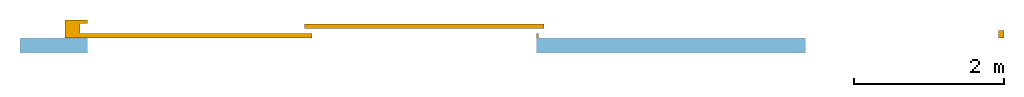
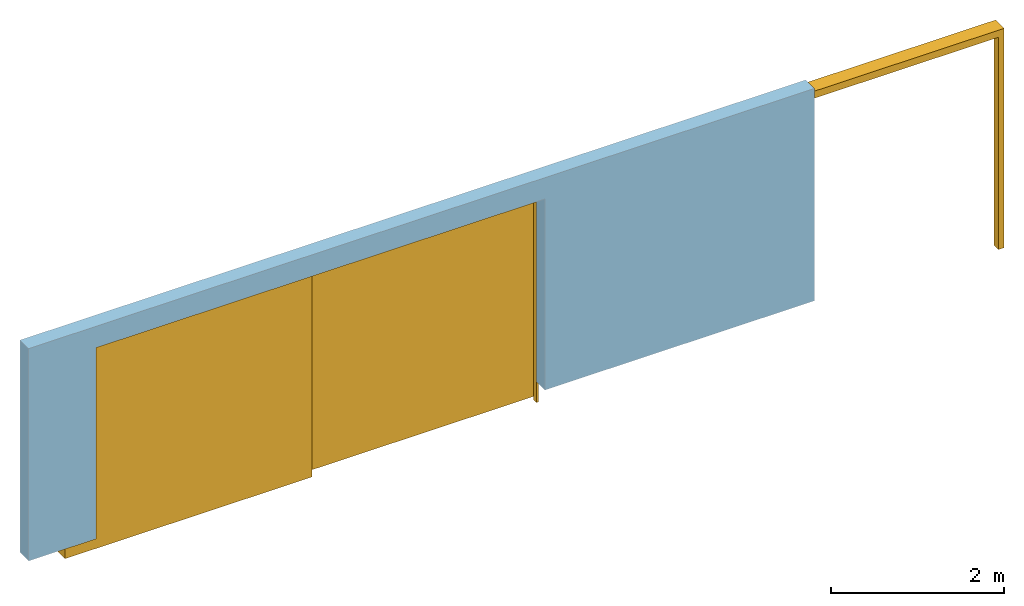
"""IFC2X3 building model written with IfcOpenShell, lengths in millimetres."""

from ifc_helpers import new_model, entity, si_unit, converted_unit, derived_unit, direction, frame, frame_2d, origin, place, context, subcontext, project, spatial, rectangle, extrude, faceted_brep, source, transform, mapped, material, material_list, layer, layer_set, layer_usage, type_object, type_shapes, element, fill, save


model = new_model("IFC2X3")

# Units and contexts
model_context = context("Model", 3, precision=0.01, world=origin(), true_north=direction((6.12303176911189e-17, 1.0)))
context_of_model = context(None, 3, precision=0.01, world=origin(), true_north=direction((6.12303176911189e-17, 1.0)))
body_context = subcontext(model_context, "Body", "Model", "MODEL_VIEW")
ifc_project = project(units=[si_unit("LENGTHUNIT", "METRE", prefix="MILLI"), si_unit("AREAUNIT", "SQUARE_METRE"), si_unit("VOLUMEUNIT", "CUBIC_METRE"), converted_unit("PLANEANGLEUNIT", "DEGREE", entity("IfcRatioMeasure", 0.0174532925199433), si_unit("PLANEANGLEUNIT", "RADIAN"), dimensions=[0, 0, 0, 0, 0, 0, 0]), si_unit("MASSUNIT", "GRAM", prefix="KILO"), si_unit("TIMEUNIT", "SECOND"), si_unit("FREQUENCYUNIT", "HERTZ"), si_unit("THERMODYNAMICTEMPERATUREUNIT", "DEGREE_CELSIUS"), derived_unit("THERMALTRANSMITTANCEUNIT", [(si_unit("MASSUNIT", "GRAM", prefix="KILO"), 1), (si_unit("THERMODYNAMICTEMPERATUREUNIT", "KELVIN"), -1), (si_unit("TIMEUNIT", "SECOND"), -3)]), derived_unit("VOLUMETRICFLOWRATEUNIT", [(si_unit("LENGTHUNIT", "METRE"), 3), (si_unit("TIMEUNIT", "SECOND"), -1)]), si_unit("ELECTRICCURRENTUNIT", "AMPERE"), si_unit("ELECTRICVOLTAGEUNIT", "VOLT"), si_unit("POWERUNIT", "WATT"), si_unit("FORCEUNIT", "NEWTON", prefix="KILO"), si_unit("ILLUMINANCEUNIT", "LUX"), si_unit("LUMINOUSFLUXUNIT", "LUMEN"), si_unit("LUMINOUSINTENSITYUNIT", "CANDELA"), si_unit("PRESSUREUNIT", "PASCAL")], contexts=[model_context, context_of_model])

# Site, building, storey
site_placement = place(None, origin())
site = spatial("IfcSite", under=ifc_project, at=site_placement, CompositionType="ELEMENT")
building_placement = place(site_placement, origin())
building = spatial("IfcBuilding", under=site, at=building_placement, CompositionType="ELEMENT")
storey_1_placement = place(building_placement, origin())
storey_1 = spatial("IfcBuildingStorey", under=building, at=storey_1_placement, CompositionType="ELEMENT", Elevation=0.0)

# Wall, opening
ifc_material_1 = material()
ifc_layer = layer(ifc_material_1, 200.0)
ifc_layer_set = layer_set([ifc_layer])
ifc_layer_usage = layer_usage(ifc_layer_set, "AXIS2", "NEGATIVE", 100.0)
wall_type = type_object("IfcWallType", PredefinedType="STANDARD", material=ifc_layer_set)
wall_placement = place(storey_1_placement, frame((-30147.0958388037, 10047.082659008, 0.0)))
wall = element("IfcWallStandardCase", 1, at=wall_placement, inside=storey_1, type_object=wall_type, material=ifc_layer_usage, context=body_context, shape_type="SweptSolid", body=[
    extrude(rectangle(XDim=10500.0, YDim=199.999999999998, at=frame_2d((5250.0, -1.4210854715202e-13), x_axis=(-1.0, 0.0))), origin(), (0.0, 0.0, 1.0), 3000.0),
])
opening_placement = place(wall_placement, frame((30147.0958388037, -10047.082659008, -300.0)))
opening = element("IfcOpeningElement", 2, at=opening_placement, cuts=wall, ObjectType="Opening", context=body_context, shape_type="SweptSolid", body=[
    extrude(rectangle(XDim=3000.0, YDim=5999.99999999998, at=frame_2d((0.0, 2.04636307898909e-12), x_axis=(1.0, 0.0))), frame((-26247.0958388037, 9607.0826590081, 1500.0), z_axis=(0.0, 1.0, 0.0), x_axis=(0.0, 0.0, -1.0)), (0.0, 0.0, 1.0), 539.999999999892),
])

# Storey
storey_2_placement = place(building_placement, frame((0.0, 0.0, -300.0)))
storey_2 = spatial("IfcBuildingStorey", under=building, at=storey_2_placement, CompositionType="ELEMENT", Elevation=-300.0)

# Door
ifc_material_2 = material()
ifc_material_3 = material()
ifc_material_list_1 = material_list([ifc_material_2, ifc_material_3])
ifc_material_list_2 = material_list([ifc_material_2, ifc_material_3])
door_style = type_object("IfcDoorStyle", ConstructionType="NOTDEFINED", OperationType="NOTDEFINED", ParameterTakesPrecedence=False, Sizeable=False, material=ifc_material_list_2)
shared_shape = source(origin(), body_context, "Body", "Brep", [
    faceted_brep([(6030.0, 60.0, 3000.0), (6000.0, 60.0, 3000.0), (6000.0, 0.0, 3000.0), (6030.0, 0.0, 3000.0), (6030.0, 60.0, 0.0), (6030.0, 0.0, 0.0), (6000.0, 0.0, 0.0), (6000.0, 60.0, 0.0)], [[[0, 1, 2, 3]], [[4, 5, 6, 7]], [[1, 0, 4, 7]], [[2, 1, 7, 6]], [[3, 2, 6, 5]], [[0, 3, 5, 4]]]),
    faceted_brep([(1000.0, 60.0, 2100.0), (200.0, 60.0, 2100.0), (200.0, 0.0, 2100.0), (1000.0, 0.0, 2100.0), (1000.0, 60.0, 0.0), (1000.0, 0.0, 0.0), (200.0, 0.0, 0.0), (200.0, 60.0, 0.0)], [[[0, 1, 2, 3]], [[4, 5, 6, 7]], [[1, 0, 4, 7]], [[2, 1, 7, 6]], [[3, 2, 6, 5]], [[0, 3, 5, 4]]]),
    faceted_brep([(12250.0, 0.0, 0.0), (12250.0, 97.4999999998478, 0.0), (12250.0, 97.4999999998478, 3000.0), (12250.0, 130.0, 3000.0), (12250.0, 130.0, 3055.0), (12250.0, 190.0, 3055.0), (12250.0, 190.0, 3000.0), (12250.0, 195.753542329384, 3000.0), (12250.0, 195.753542329384, 3100.0), (12250.0, 0.0, 3100.0), (12174.6192199623, 68.2535423293689, 3000.0), (-97.4479022578299, 68.2535423293683, 3000.0), (-97.4479022578299, 130.0, 3000.0), (12174.6192199623, 97.4999999998478, 3000.0), (12174.6192199623, 68.2535423293689, 3048.16794527357), (-97.4479022578299, 68.2535423293683, 3048.16794527357), (12174.6192199623, 8.2535423293976, 3048.16794527357), (-97.4479022578299, 8.25354232939701, 3048.16794527357), (12174.6192199623, 8.2535423293976, 3000.0), (-97.4479022578299, 8.25354232939701, 3000.0), (12174.6192199623, 0.0, 3000.0), (-97.4479022578299, 0.0, 3000.0), (12174.6192199623, 0.0, 0.0), (-300.0, 0.0, 3100.0), (-300.0, 0.0, 0.0), (-97.447902257829, 0.0, 0.0), (0.0, 195.753542329384, 3100.0), (0.0, 240.0, 3100.0), (-300.0, 240.0, 3100.0), (12174.6192199623, 97.4999999998478, 0.0), (0.0, 195.753542329384, 3000.0), (-97.4479022578299, 190.0, 3000.0), (-97.4479022578299, 193.732320680007, 3000.0), (0.0, 193.732320680007, 3000.0), (-97.4479022578299, 190.0, 3055.0), (-97.4479022578299, 130.0, 3055.0), (-97.447902257829, 193.732320680007, 0.0), (-300.0, 240.0, 0.0), (0.0, 240.0, 0.0), (0.0, 193.732320680007, 0.0)], [[[0, 1, 2, 3, 4, 5, 6, 7, 8, 9]], [[10, 11, 12, 3, 2, 13]], [[11, 10, 14, 15]], [[15, 14, 16, 17]], [[17, 16, 18, 19]], [[19, 18, 20, 21]], [[22, 0, 9, 23, 24, 25, 21, 20]], [[23, 9, 8, 26, 27, 28]], [[0, 22, 29, 1]], [[29, 22, 20, 18, 16, 14, 10, 13]], [[1, 29, 13, 2]], [[8, 7, 30, 26]], [[7, 6, 31, 32, 33, 30]], [[6, 5, 34, 31]], [[5, 4, 35, 34]], [[4, 3, 12, 35]], [[36, 25, 24, 37, 38, 39]], [[36, 39, 33, 32]], [[39, 38, 27, 26, 30, 33]], [[28, 27, 38, 37]], [[23, 28, 37, 24]], [[25, 36, 32, 31, 34, 35, 12, 11, 15, 17, 19, 21]]]),
    faceted_brep([(6100.0, 125.0, 3000.0), (6100.0, 185.0, 3000.0), (2900.0, 185.0, 3000.0), (2900.0, 125.0, 3000.0), (6100.0, 125.0, 0.0), (2900.0, 125.0, 0.0), (2900.0, 185.0, 0.0), (6100.0, 185.0, 0.0)], [[[0, 1, 2, 3]], [[4, 5, 6, 7]], [[0, 3, 5, 4]], [[3, 2, 6, 5]], [[2, 1, 7, 6]], [[1, 0, 4, 7]]]),
    faceted_brep([(3000.0, 0.0, 3000.0), (3000.0, 60.0, 3000.0), (-97.4479022578288, 60.0, 3000.0), (-97.4479022578288, 0.0, 3000.0), (3000.0, 0.0, 0.0), (-97.4479022578288, 0.0, 0.0), (-97.4479022578288, 60.0, 0.0), (3000.0, 60.0, 0.0)], [[[0, 1, 2, 3]], [[4, 5, 6, 7]], [[0, 3, 5, 4]], [[3, 2, 6, 5]], [[2, 1, 7, 6]], [[1, 0, 4, 7]]]),
    faceted_brep([(2743.66159845671, 60.0, 250.0), (2543.66159845671, 60.0, 250.0), (2543.66159845671, 0.0, 250.0), (2743.66159845671, 0.0, 250.0), (2743.66159845671, 60.0, 50.0), (2743.66159845671, 0.0, 50.0), (2543.66159845671, 0.0, 50.0), (2543.66159845671, 60.0, 50.0)], [[[0, 1, 2, 3]], [[4, 5, 6, 7]], [[1, 0, 4, 7]], [[2, 1, 7, 6]], [[3, 2, 6, 5]], [[0, 3, 5, 4]]]),
])
type_shapes(door_style, [shared_shape])
door_placement = place(opening_placement, frame((-29247.0958388037, 10147.082659008, 0.0)))
door = element("IfcDoor", 3, at=door_placement, inside=storey_2, type_object=door_style, material=ifc_material_list_1, OverallHeight=5999.99999999998, OverallWidth=3000.0, context=body_context, shape_type="MappedRepresentation", body=[
    mapped(shared_shape, transform((0.0, 0.0, 0.0), scale=1.0)),
])

fill(opening, door)

save(model, "model.ifc")
